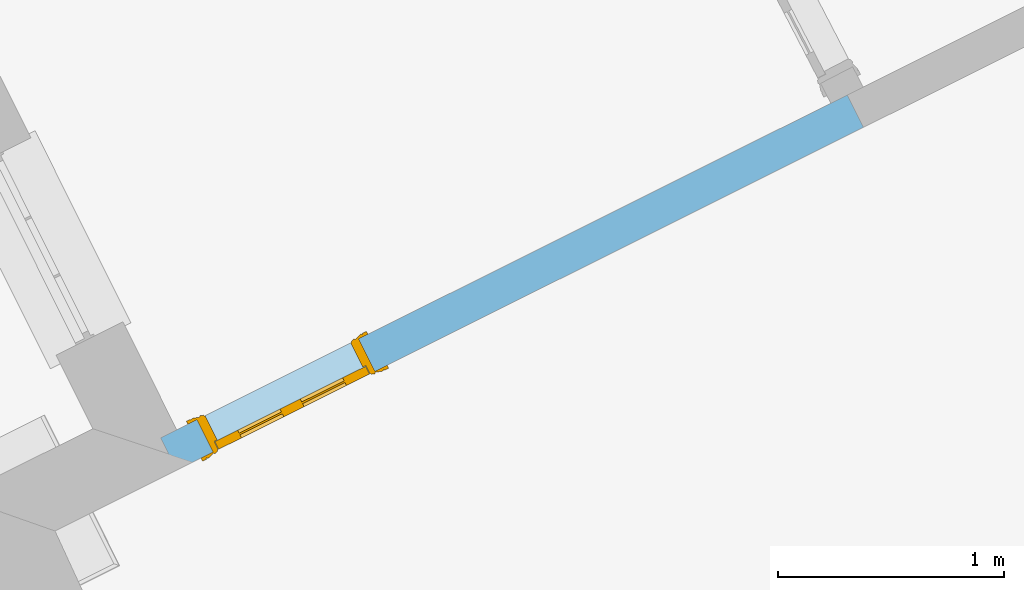
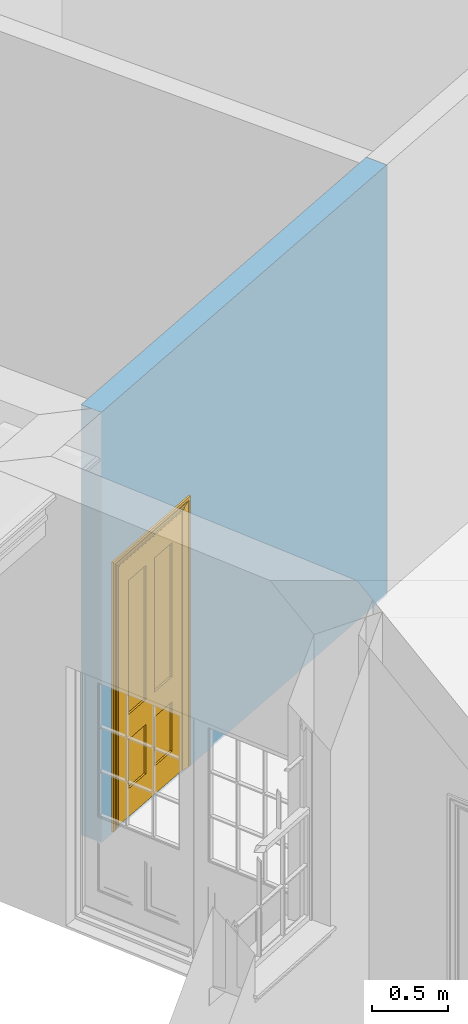
# One storey, part 5 of 10: 1 door, 1 opening, plus 1 element that does not belong to this part.
"""IFC2X3 building model written with IfcOpenShell, lengths in metres."""

from ifc_helpers import new_model, si_unit, frame, origin, place, context, subcontext, project, spatial, polyline, outline, extrude, faceted_brep, material, layer, layer_set, layer_usage, element, fill, save


model = new_model("IFC2X3")

# Units and contexts
model_context = context("Model", 3, world=origin())
body_context = subcontext(model_context, "Body", "Model", "MODEL_VIEW")
ifc_project = project(units=[si_unit("PLANEANGLEUNIT", "RADIAN"), si_unit("MASSUNIT", "GRAM", prefix="KILO"), si_unit("FORCEUNIT", "NEWTON", prefix="KILO"), si_unit("LENGTHUNIT", "METRE")], contexts=[model_context])

# Site, building, storey
site_placement = place(None, origin())
site = spatial("IfcSite", under=ifc_project, at=site_placement, CompositionType="ELEMENT")
building_placement = place(None, origin())
building = spatial("IfcBuilding", under=site, at=building_placement, Name="Building plot-8", CompositionType="ELEMENT")
storey_placement = place(None, origin())
storey = spatial("IfcBuildingStorey", under=building, at=storey_placement, Name="Floor 0", CompositionType="ELEMENT", Elevation=0.0)

# Wall, opening, door
ifc_material = material(Name="Masonry")
ifc_layer = layer(ifc_material, 0.16, ventilated=False)
ifc_layer_set = layer_set([ifc_layer], Name="My Wall")
ifc_layer_usage = layer_usage(ifc_layer_set, "AXIS2", "NEGATIVE", 0.08)
wall_placement = place(storey_placement, origin())
wall = element("IfcWallStandardCase", 1, at=wall_placement, inside=storey, material=ifc_layer_usage, Name="interior", context=body_context, shape_type="SweptSolid", body=[
    extrude(outline(polyline([(27.4817132172852, 14.7989349376481), (27.4102456579562, 14.9420865634283), (24.3718074749693, 13.4251651877418), (24.4432750342983, 13.2820135619616), (27.4817132172852, 14.7989349376481)])), origin(), (0.0, 0.0, 1.0), 3.45),
])
opening_placement = place(storey_placement, frame((0.0, 0.0, 0.02)))
opening = element("IfcOpeningElement", 2, at=opening_placement, cuts=wall, Name="Opening", ObjectType="Opening", context=body_context, shape_type="SweptSolid", body=[
    extrude(outline(polyline([(25.2486111828736, 13.8629039886326), (24.5328530539721, 13.5055661919871), (24.6043206133012, 13.3624145662068), (25.3200787422027, 13.7197523628523), (25.2486111828736, 13.8629039886326)])), origin(), (0.0, 0.0, 1.0), 2.1),
])
door_placement = place(storey_placement, frame((25.2843449625381, 13.7913281757424, 0.02), z_axis=(0.0, 0.0, 1.0), x_axis=(-0.715758128901484, -0.35733779664548, 0.0)))
door = element("IfcDoor", 3, at=door_placement, inside=storey, Name="living inside door", OverallHeight=2.1, OverallWidth=0.8, context=body_context, shape_type="Brep", held_by="IfcProductRepresentation", body=[
    faceted_brep([(0.773, 0.08, 1.895), (0.66, 0.08, 1.895), (0.66, 0.08, 2.073), (0.773, 0.08, 2.073), (0.773, 0.08, 0.82), (0.66, 0.08, 0.82), (0.45, 0.08, 1.895), (0.45, 0.08, 2.073), (0.773, 0.08, 0.62), (0.66, 0.08, 0.62), (0.66, 0.065, 0.82), (0.66, 0.065, 1.895), (0.45, 0.065, 1.895), (0.35, 0.08, 1.895), (0.35, 0.08, 2.073), (0.773, 0.08, 0.225), (0.66, 0.08, 0.225), (0.45, 0.08, 0.62), (0.45, 0.08, 0.82), (0.45, 0.065, 0.82), (0.35, 0.08, 0.82), (0.14, 0.08, 2.073), (0.14, 0.08, 1.895), (0.773, 0.08, 0.0), (0.66, 0.08, 0.0), (0.66, 0.065, 0.225), (0.66, 0.065, 0.62), (0.45, 0.065, 0.62), (0.35, 0.08, 0.62), (0.35, 0.065, 0.82), (0.35, 0.065, 1.895), (0.14, 0.065, 1.895), (0.027, 0.08, 2.073), (0.027, 0.08, 1.895), (0.773, 0.042, 0.0), (0.66, 0.042, 0.0), (0.45, 0.08, 0.0), (0.45, 0.08, 0.225), (0.45, 0.065, 0.225), (0.35, 0.08, 0.225), (0.14, 0.08, 0.82), (0.14, 0.08, 0.62), (0.14, 0.065, 0.82), (0.027, 0.08, 0.82), (0.773, 0.042, 0.225), (0.66, 0.042, 0.225), (0.45, 0.042, 0.0), (0.35, 0.08, 0.0), (0.35, 0.065, 0.225), (0.35, 0.065, 0.62), (0.14, 0.065, 0.62), (0.027, 0.08, 0.62), (0.773, 0.042, 0.62), (0.66, 0.042, 0.62), (0.45, 0.042, 0.225), (0.35, 0.042, 0.0), (0.14, 0.08, 0.225), (0.14, 0.08, 0.0), (0.14, 0.065, 0.225), (0.027, 0.08, 0.225), (0.773, 0.042, 0.82), (0.66, 0.042, 0.82), (0.66, 0.057, 0.62), (0.66, 0.057, 0.225), (0.45, 0.057, 0.225), (0.35, 0.042, 0.225), (0.14, 0.042, 0.0), (0.027, 0.08, 0.0), (0.773, 0.042, 1.895), (0.66, 0.042, 1.895), (0.45, 0.042, 0.62), (0.45, 0.042, 0.82), (0.45, 0.057, 0.62), (0.35, 0.042, 0.62), (0.14, 0.042, 0.225), (0.027, 0.042, 0.0), (0.773, 0.042, 2.073), (0.66, 0.042, 2.073), (0.66, 0.057, 1.895), (0.66, 0.057, 0.82), (0.45, 0.057, 0.82), (0.35, 0.042, 0.82), (0.35, 0.057, 0.62), (0.35, 0.057, 0.225), (0.14, 0.057, 0.225), (0.027, 0.042, 0.225), (0.45, 0.042, 1.895), (0.45, 0.042, 2.073), (0.45, 0.057, 1.895), (0.35, 0.042, 1.895), (0.14, 0.042, 0.82), (0.14, 0.042, 0.62), (0.14, 0.057, 0.62), (0.027, 0.042, 0.62), (0.35, 0.042, 2.073), (0.35, 0.057, 1.895), (0.35, 0.057, 0.82), (0.14, 0.057, 0.82), (0.027, 0.042, 0.82), (0.14, 0.042, 2.073), (0.14, 0.042, 1.895), (0.14, 0.057, 1.895), (0.027, 0.042, 1.895), (0.027, 0.042, 2.073), (0.02, 0.085, 0.0), (0.005, 0.09, 0.0), (0.005, 0.09, 2.095), (0.02, 0.085, 2.08), (0.02, 0.08, 0.0), (0.0, 0.085, 0.0), (0.0, 0.085, 2.1), (0.795, 0.09, 2.095), (0.78, 0.085, 2.08), (0.02, 0.08, 2.08), (0.0, 0.08, 0.0), (-0.032, 0.095, 0.0), (-0.032, 0.095, 2.132), (0.8, 0.085, 2.1), (0.795, 0.09, 0.0), (0.78, 0.085, 0.0), (0.78, 0.08, 2.08), (0.04, 0.04, 0.0), (0.025, 0.04, 0.0), (0.025, 0.04, 2.075), (0.04, 0.04, 2.06), (-0.04, 0.09, 0.0), (-0.04, 0.09, 2.14), (0.832, 0.095, 2.132), (0.8, 0.085, 0.0), (0.78, 0.08, 0.0), (0.8, 0.08, 0.0), (0.86, 0.08, 0.0), (0.86, 0.08, 2.16), (0.8, 0.08, 2.1), (-0.06, 0.08, 2.16), (0.0, 0.08, 2.1), (-0.06, 0.08, 0.0), (-0.04, 0.095, 0.0), (-0.04, 0.095, 2.14), (0.84, 0.09, 2.14), (0.832, 0.095, 0.0), (0.84, 0.09, 0.0), (0.86, 0.095, 0.0), (0.86, 0.095, 2.16), (-0.06, 0.095, 2.16), (-0.06, 0.095, 0.0), (0.84, 0.095, 0.0), (0.84, 0.095, 2.14), (-0.025, -0.095, 0.0), (-0.025, -0.09, 0.0), (-0.025, -0.09, 2.125), (-0.025, -0.095, 2.125), (-0.017, -0.095, 0.0), (-0.017, -0.095, 2.117), (0.825, -0.09, 2.125), (0.825, -0.095, 2.125), (0.825, -0.095, 0.0), (0.845, -0.095, 0.0), (-0.045, -0.095, 2.145), (-0.045, -0.095, 0.0), (0.845, -0.095, 2.145), (0.015, -0.085, 0.0), (0.015, -0.085, 2.085), (0.817, -0.095, 2.117), (0.825, -0.09, 0.0), (0.845, -0.08, 0.0), (0.845, -0.08, 2.145), (-0.045, -0.08, 2.145), (-0.045, -0.08, 0.0), (0.02, -0.09, 0.0), (0.02, -0.09, 2.08), (0.785, -0.085, 2.085), (0.817, -0.095, 0.0), (0.8, -0.08, 0.0), (0.8, -0.08, 2.1), (0.0, -0.08, 2.1), (0.0, -0.08, 0.0), (0.035, -0.085, 0.0), (0.035, -0.085, 2.065), (0.78, -0.09, 2.08), (0.785, -0.085, 0.0), (0.775, 0.04, 2.075), (0.76, 0.04, 2.06), (0.035, -0.08, 2.065), (0.035, -0.08, 0.0), (0.765, -0.085, 2.065), (0.78, -0.09, 0.0), (0.765, -0.08, 0.0), (0.765, -0.08, 2.065), (0.765, -0.085, 0.0), (0.04, -0.08, 2.06), (0.04, -0.08, 0.0), (0.76, -0.08, 2.06), (0.76, -0.08, 0.0), (0.76, 0.04, 0.0), (0.775, 0.04, 0.0), (0.025, 0.08, 0.0), (0.025, 0.08, 2.075), (0.775, 0.08, 0.0), (0.775, 0.08, 2.075)], [[[0, 1, 2, 3]], [[1, 0, 4, 5]], [[1, 6, 7, 2]], [[8, 9, 5, 4]], [[1, 5, 10, 11]], [[6, 1, 11, 12]], [[6, 13, 14, 7]], [[15, 16, 9, 8]], [[9, 17, 18, 5]], [[5, 18, 19, 10]], [[10, 19, 12, 11]], [[18, 6, 12, 19]], [[18, 20, 13, 6]], [[21, 14, 13, 22]], [[23, 24, 16, 15]], [[9, 16, 25, 26]], [[17, 9, 26, 27]], [[17, 28, 20, 18]], [[13, 20, 29, 30]], [[22, 13, 30, 31]], [[32, 21, 22, 33]], [[34, 35, 24, 23]], [[24, 36, 37, 16]], [[16, 37, 38, 25]], [[25, 38, 27, 26]], [[37, 17, 27, 38]], [[37, 39, 28, 17]], [[40, 20, 28, 41]], [[20, 40, 42, 29]], [[31, 30, 29, 42]], [[40, 22, 31, 42]], [[33, 22, 40, 43]], [[35, 34, 44, 45]], [[35, 46, 36, 24]], [[36, 47, 39, 37]], [[28, 39, 48, 49]], [[41, 28, 49, 50]], [[43, 40, 41, 51]], [[45, 44, 52, 53]], [[46, 35, 45, 54]], [[46, 55, 47, 36]], [[56, 39, 47, 57]], [[39, 56, 58, 48]], [[50, 49, 48, 58]], [[56, 41, 50, 58]], [[51, 41, 56, 59]], [[53, 52, 60, 61]], [[45, 53, 62, 63]], [[54, 45, 63, 64]], [[55, 46, 54, 65]], [[55, 66, 57, 47]], [[59, 56, 57, 67]], [[61, 60, 68, 69]], [[70, 53, 61, 71]], [[53, 70, 72, 62]], [[72, 64, 63, 62]], [[70, 54, 64, 72]], [[65, 54, 70, 73]], [[65, 74, 66, 55]], [[67, 57, 66, 75]], [[69, 68, 76, 77]], [[61, 69, 78, 79]], [[71, 61, 79, 80]], [[73, 70, 71, 81]], [[65, 73, 82, 83]], [[74, 65, 83, 84]], [[74, 85, 75, 66]], [[86, 69, 77, 87]], [[69, 86, 88, 78]], [[88, 80, 79, 78]], [[86, 71, 80, 88]], [[81, 71, 86, 89]], [[73, 81, 90, 91]], [[73, 91, 92, 82]], [[83, 82, 92, 84]], [[91, 74, 84, 92]], [[91, 93, 85, 74]], [[89, 86, 87, 94]], [[81, 89, 95, 96]], [[90, 81, 96, 97]], [[90, 98, 93, 91]], [[94, 99, 100, 89]], [[89, 100, 101, 95]], [[101, 97, 96, 95]], [[100, 90, 97, 101]], [[100, 102, 98, 90]], [[99, 103, 102, 100]], [[32, 103, 99, 21]], [[102, 103, 32, 33]], [[98, 102, 33, 43]], [[21, 99, 94, 14]], [[94, 87, 7, 14]], [[7, 87, 77, 2]], [[76, 3, 2, 77]], [[43, 51, 93, 98]], [[51, 59, 85, 93]], [[67, 75, 85, 59]], [[34, 23, 15, 44]], [[44, 15, 8, 52]], [[52, 8, 4, 60]], [[0, 68, 60, 4]], [[0, 3, 76, 68]], [[104, 105, 106, 107]], [[104, 108, 109, 105]], [[105, 109, 110, 106]], [[107, 106, 111, 112]], [[107, 113, 108, 104]], [[114, 109, 108]], [[109, 115, 116, 110]], [[106, 110, 117, 111]], [[112, 111, 118, 119]], [[113, 107, 112, 120]], [[121, 122, 123, 124]], [[115, 109, 114, 125]], [[115, 125, 126, 116]], [[110, 116, 127, 117]], [[111, 117, 128, 118]], [[118, 128, 129, 119]], [[120, 112, 119, 129]], [[130, 129, 128]], [[130, 131, 132, 133]], [[133, 132, 134, 135]], [[135, 134, 136, 114]], [[136, 125, 114]], [[125, 137, 138, 126]], [[116, 126, 139, 127]], [[117, 127, 140, 128]], [[141, 130, 128, 140]], [[131, 130, 141]], [[131, 142, 143, 132]], [[132, 143, 144, 134]], [[134, 144, 145, 136]], [[137, 125, 136, 145]], [[143, 142, 146]], [[143, 146, 147]], [[137, 145, 144]], [[143, 147, 138]], [[138, 137, 144]], [[143, 138, 144]], [[126, 138, 147, 139]], [[127, 139, 141, 140]], [[142, 131, 141, 146]], [[139, 147, 146, 141]], [[148, 149, 150, 151]], [[149, 152, 153, 150]], [[151, 150, 154, 155]], [[155, 156, 157]], [[158, 159, 148]], [[158, 148, 151]], [[155, 157, 160]], [[158, 151, 155]], [[155, 160, 158]], [[152, 161, 162, 153]], [[150, 153, 163, 154]], [[155, 154, 164, 156]], [[156, 164, 165, 157]], [[157, 165, 166, 160]], [[160, 166, 167, 158]], [[158, 167, 168, 159]], [[161, 169, 170, 162]], [[153, 162, 171, 163]], [[154, 163, 172, 164]], [[165, 164, 173]], [[165, 173, 174, 166]], [[166, 174, 175, 167]], [[167, 175, 176, 168]], [[169, 177, 178, 170]], [[162, 170, 179, 171]], [[163, 171, 180, 172]], [[172, 180, 173, 164]], [[124, 123, 181, 182]], [[183, 178, 177, 184]], [[170, 178, 185, 179]], [[171, 179, 186, 180]], [[187, 173, 180]], [[185, 188, 187, 189]], [[188, 185, 178, 183]], [[179, 185, 189, 186]], [[189, 187, 180, 186]], [[190, 183, 184, 191]], [[192, 188, 183, 190]], [[191, 184, 122, 121]], [[124, 190, 191, 121]], [[193, 187, 188, 192]], [[182, 192, 190, 124]], [[184, 176, 122]], [[194, 195, 187, 193]], [[192, 182, 194, 193]], [[161, 176, 184]], [[114, 108, 122, 176]], [[173, 187, 195]], [[152, 149, 176, 161]], [[169, 161, 184, 177]], [[196, 122, 108]], [[176, 175, 135, 114]], [[173, 195, 129, 130]], [[176, 149, 168]], [[123, 122, 196, 197]], [[196, 108, 113, 197]], [[175, 174, 133, 135]], [[198, 129, 195]], [[133, 174, 173, 130]], [[159, 168, 149, 148]], [[181, 123, 197, 199]], [[197, 113, 120, 199]], [[199, 120, 129, 198]], [[195, 181, 199, 198]], [[195, 194, 182, 181]]]),
])
fill(opening, door)

save(model, "model.ifc")
